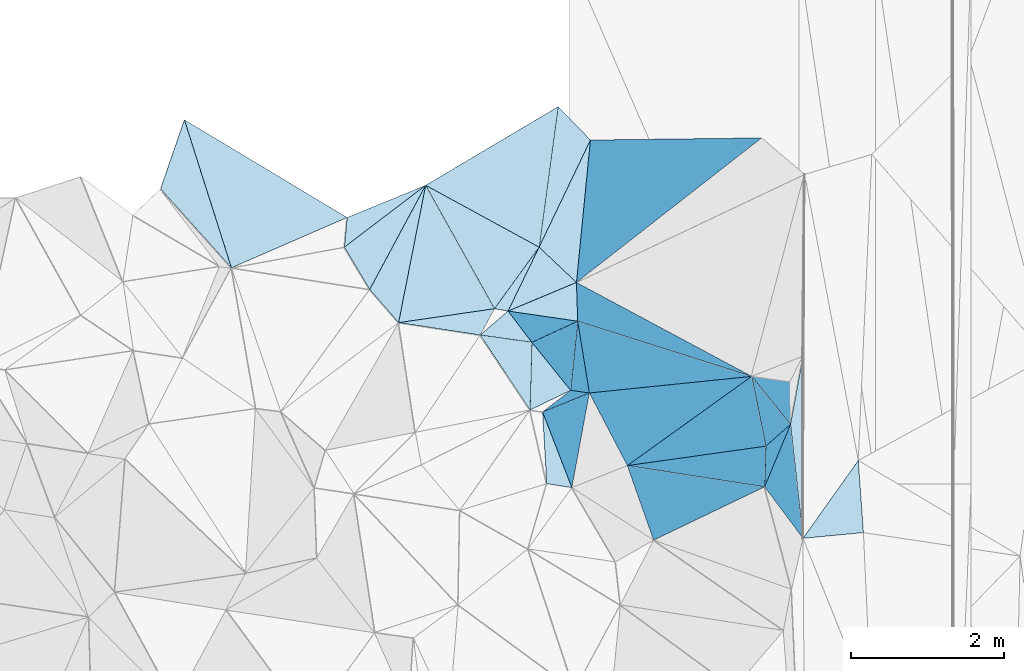
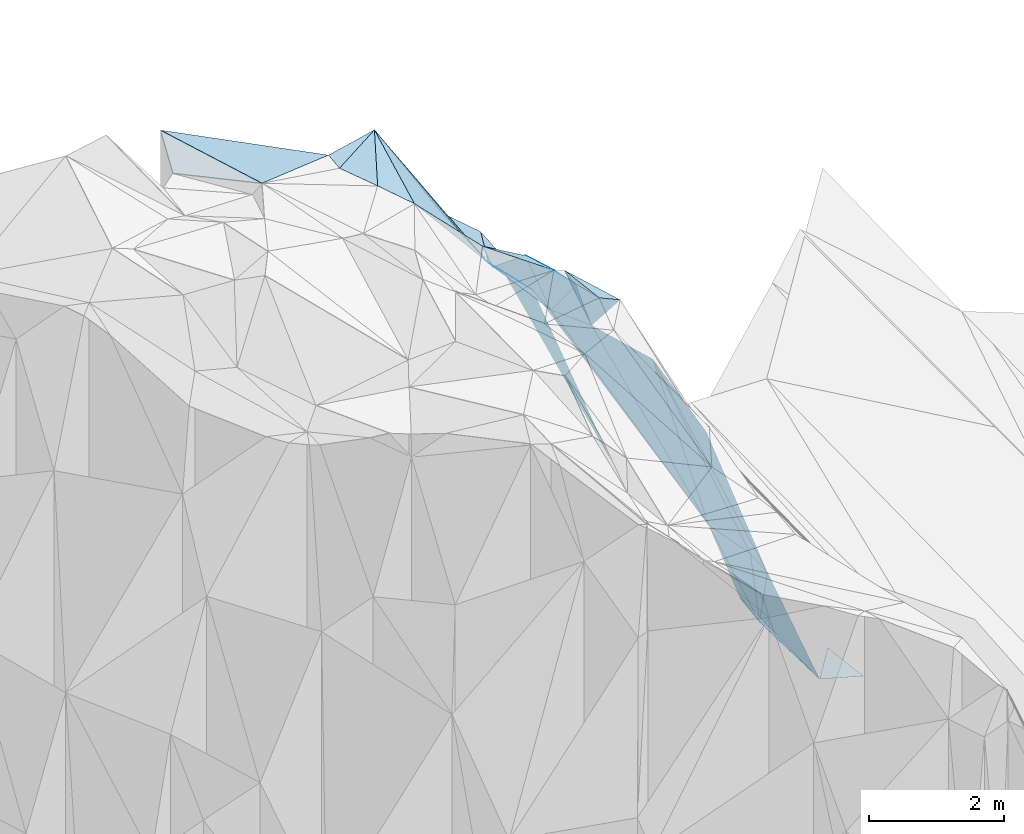
# One storey, part 143 of 275: 36 plates.
"""IFC2X3 building model written with IfcOpenShell, lengths in millimetres."""

from ifc_helpers import new_model, si_unit, frame, origin_with_axes, place, context, subcontext, project, spatial, polyline, outline, extrude, material, type_object, element, save


model = new_model("IFC2X3")

# Units and contexts
model_context = context("Model", 3, precision=1e-05, world=origin_with_axes())
body_context = subcontext(model_context, "Body", "Model", "MODEL_VIEW")
ifc_project = project(units=[si_unit("LENGTHUNIT", "METRE", prefix="MILLI"), si_unit("AREAUNIT", "SQUARE_METRE"), si_unit("VOLUMEUNIT", "CUBIC_METRE"), si_unit("MASSUNIT", "GRAM", prefix="KILO"), si_unit("TIMEUNIT", "SECOND"), si_unit("PLANEANGLEUNIT", "RADIAN"), si_unit("SOLIDANGLEUNIT", "STERADIAN"), si_unit("THERMODYNAMICTEMPERATUREUNIT", "DEGREE_CELSIUS"), si_unit("LUMINOUSINTENSITYUNIT", "LUMEN")], contexts=[model_context])

# Site, building, storey
site_placement = place(None, origin_with_axes())
site = spatial("IfcSite", under=ifc_project, at=site_placement, CompositionType="ELEMENT")
building_placement = place(site_placement, origin_with_axes())
building = spatial("IfcBuilding", under=site, at=building_placement, Name="Undefined", CompositionType="ELEMENT")
storey_placement = place(building_placement, origin_with_axes())
storey = spatial("IfcBuildingStorey", under=building, at=storey_placement, Name="Undefined", CompositionType="ELEMENT", Elevation=0.0)

# Plates
ifc_material = material()
plate_type_1 = type_object("IfcPlateType", PredefinedType="NOTDEFINED")
plate_1_placement = place(storey_placement, frame((-102547.720797669, 135900.673619352, 52969.6947280078), z_axis=(-0.768363652866113, 0.192112177664425, -0.610499965722583), x_axis=(0.364064629516418, -0.653326157836774, -0.663793549999781)))
element("IfcPlate", 1, at=plate_1_placement, inside=storey, type_object=plate_type_1, material=ifc_material, Name="00", context=body_context, shape_type="SweptSolid", body=[
    extrude(outline(polyline([(0.0, 0.0), (2470.64770507813, 2.22753442358226e-08), (1124.52294921875, 1449.94763183594), (0.0, 0.0)])), frame((-8.85201319254618e-08, 2.18876761149539e-07, -0.5000001331573), z_axis=(0.0, 0.0, 1.0), x_axis=(1.0, 0.0, 0.0)), (0.0, 0.0, 1.0), 1.0),
])
plate_type_2 = type_object("IfcPlateType", PredefinedType="NOTDEFINED")
plate_2_placement = place(storey_placement, frame((-101470.606874109, 134255.650710094, 51119.665579446), z_axis=(-0.742247574985633, 0.0421685093330211, -0.668797693064636), x_axis=(0.652550710898406, 0.272550598345937, -0.707031640768118)))
element("IfcPlate", 2, at=plate_2_placement, inside=storey, type_object=plate_type_2, material=ifc_material, Name="00", context=body_context, shape_type="SweptSolid", body=[
    extrude(outline(polyline([(0.0, 0.0), (1371.93298339844, 2.2409949451685e-09), (1279.80017089844, 501.010528564453), (0.0, 0.0)])), frame((-8.85201319254618e-08, 2.18876761149539e-07, -0.5000001331573), z_axis=(0.0, 0.0, 1.0), x_axis=(1.0, 0.0, 0.0)), (0.0, 0.0, 1.0), 1.0),
])
plate_type_3 = type_object("IfcPlateType", PredefinedType="NOTDEFINED")
plate_3_placement = place(storey_placement, frame((-100559.148900787, 134122.735133682, 50099.7876835588), z_axis=(-0.870193036544903, -0.249975786762765, -0.424589431311118), x_axis=(0.467735877350666, -0.148233062743745, -0.871349590089197)))
element("IfcPlate", 3, at=plate_3_placement, inside=storey, type_object=plate_type_3, material=ifc_material, Name="00", context=body_context, shape_type="SweptSolid", body=[
    extrude(outline(polyline([(0.0, 0.0), (4866.0146484375, 1.09575921669602e-08), (1.31524467468262, 980.611145019531), (0.0, 0.0)])), frame((-8.85201319254618e-08, 2.18876761149539e-07, -0.5000001331573), z_axis=(0.0, 0.0, 1.0), x_axis=(1.0, 0.0, 0.0)), (0.0, 0.0, 1.0), 1.0),
])
plate_type_4 = type_object("IfcPlateType", PredefinedType="NOTDEFINED")
plate_4_placement = place(storey_placement, frame((-99909.9735898074, 132233.879680384, 50129.7923177024), z_axis=(-0.840654594332823, -0.347576580985384, -0.415319603892746), x_axis=(-0.454552533351274, 0.869738022446683, 0.192192004866156)))
element("IfcPlate", 4, at=plate_4_placement, inside=storey, type_object=plate_type_4, material=ifc_material, Name="00", context=body_context, shape_type="SweptSolid", body=[
    extrude(outline(polyline([(0.0, 0.0), (1092.65734863281, 1.22454366646707e-08), (-544.72705078125, 4684.64208984375), (0.0, 0.0)])), frame((-8.85201319254618e-08, 2.18876761149539e-07, -0.5000001331573), z_axis=(0.0, 0.0, 1.0), x_axis=(1.0, 0.0, 0.0)), (0.0, 0.0, 1.0), 1.0),
])
plate_type_5 = type_object("IfcPlateType", PredefinedType="NOTDEFINED")
plate_5_placement = place(storey_placement, frame((-101018.126795717, 132935.76946467, 51699.5332070584), z_axis=(-0.351574158053938, -0.0699814600560976, -0.933540682904115), x_axis=(0.360018159528219, -0.930620478831884, -0.0658213429567414)))
element("IfcPlate", 5, at=plate_5_placement, inside=storey, type_object=plate_type_5, material=ifc_material, Name="00", context=body_context, shape_type="SweptSolid", body=[
    extrude(outline(polyline([(0.0, 0.0), (1063.48486328125, -1.35696609504521e-08), (889.340393066406, 308.015747070313), (0.0, 0.0)])), frame((-8.85201319254618e-08, 2.18876761149539e-07, -0.5000001331573), z_axis=(0.0, 0.0, 1.0), x_axis=(1.0, 0.0, 0.0)), (0.0, 0.0, 1.0), 1.0),
])
plate_type_6 = type_object("IfcPlateType", PredefinedType="NOTDEFINED")
plate_6_placement = place(storey_placement, frame((-97775.7304442848, 132773.037217911, 44309.8717734789), z_axis=(-0.963699497185526, -0.0744148932792929, -0.256409248629209), x_axis=(0.108264988592675, -0.986789240296782, -0.120522560043873)))
element("IfcPlate", 6, at=plate_6_placement, inside=storey, type_object=plate_type_6, material=ifc_material, Name="00", context=body_context, shape_type="SweptSolid", body=[
    extrude(outline(polyline([(0.0, 0.0), (1510.09069824219, 1.77969923242927e-08), (587.242858886719, 1648.31604003906), (0.0, 0.0)])), frame((-8.85201319254618e-08, 2.18876761149539e-07, -0.5000001331573), z_axis=(0.0, 0.0, 1.0), x_axis=(1.0, 0.0, 0.0)), (0.0, 0.0, 1.0), 1.0),
])
plate_type_7 = type_object("IfcPlateType", PredefinedType="NOTDEFINED")
plate_7_placement = place(storey_placement, frame((-101063.819890666, 135091.404585895, 50539.6495673656), z_axis=(-0.698116633148106, -0.146566528724808, -0.70082195968699), x_axis=(0.628495325731104, -0.594318196787003, -0.501776351078844)))
element("IfcPlate", 7, at=plate_7_placement, inside=storey, type_object=plate_type_7, material=ifc_material, Name="00", context=body_context, shape_type="SweptSolid", body=[
    extrude(outline(polyline([(0.0, 0.0), (777.238708496094, 2.08819983527064e-09), (-49.9203147888184, 1094.53552246094), (0.0, 0.0)])), frame((-8.85201319254618e-08, 2.18876761149539e-07, -0.5000001331573), z_axis=(0.0, 0.0, 1.0), x_axis=(1.0, 0.0, 0.0)), (0.0, 0.0, 1.0), 1.0),
])
plate_type_8 = type_object("IfcPlateType", PredefinedType="NOTDEFINED")
plate_8_placement = place(storey_placement, frame((-102547.755945151, 135900.617595115, 52969.7305922935), z_axis=(-0.838638010250996, 0.0800739932029449, -0.538771234732131), x_axis=(0.501311733251364, -0.273347609580305, -0.820955315739686)))
element("IfcPlate", 8, at=plate_8_placement, inside=storey, type_object=plate_type_8, material=ifc_material, Name="00", context=body_context, shape_type="SweptSolid", body=[
    extrude(outline(polyline([(0.0, 0.0), (2959.96630859375, -3.63797880709171e-10), (2238.50537109375, 1045.55920410156), (0.0, 0.0)])), frame((-8.85201319254618e-08, 2.18876761149539e-07, -0.5000001331573), z_axis=(0.0, 0.0, 1.0), x_axis=(1.0, 0.0, 0.0)), (0.0, 0.0, 1.0), 1.0),
])
plate_type_9 = type_object("IfcPlateType", PredefinedType="NOTDEFINED")
plate_9_placement = place(storey_placement, frame((-97611.9167991548, 131282.906813317, 44127.5263774031), z_axis=(-0.316264151614978, -0.0526468642125146, -0.947209213474957), x_axis=(0.563116994412564, 0.79311296105914, -0.232101446793775)))
element("IfcPlate", 9, at=plate_9_placement, inside=storey, type_object=plate_type_9, material=ifc_material, Name="00", context=body_context, shape_type="SweptSolid", body=[
    extrude(outline(polyline([(0.0, 0.0), (1283.92138671875, 1.2019881978631e-08), (566.579895019531, 617.107177734375), (0.0, 0.0)])), frame((-8.85201319254618e-08, 2.18876761149539e-07, -0.5000001331573), z_axis=(0.0, 0.0, 1.0), x_axis=(1.0, 0.0, 0.0)), (0.0, 0.0, 1.0), 1.0),
])
plate_type_10 = type_object("IfcPlateType", PredefinedType="NOTDEFINED")
plate_10_placement = place(storey_placement, frame((-98283.1765916622, 133401.575000467, 45859.8375277752), z_axis=(-0.944972946793245, 0.0382884073400537, -0.324900181120685), x_axis=(0.32307635621108, -0.0469877747993295, -0.945205700933283)))
element("IfcPlate", 10, at=plate_10_placement, inside=storey, type_object=plate_type_10, material=ifc_material, Name="00", context=body_context, shape_type="SweptSolid", body=[
    extrude(outline(polyline([(0.0, 0.0), (1555.21704101563, -2.05182004719973e-09), (1658.54663085938, 551.564147949219), (0.0, 0.0)])), frame((-8.85201319254618e-08, 2.18876761149539e-07, -0.5000001331573), z_axis=(0.0, 0.0, 1.0), x_axis=(1.0, 0.0, 0.0)), (0.0, 0.0, 1.0), 1.0),
])
plate_type_11 = type_object("IfcPlateType", PredefinedType="NOTDEFINED")
plate_11_placement = place(storey_placement, frame((-101648.186491519, 134286.2018043, 51329.7033202334), z_axis=(-0.650613746785021, -0.474003135917019, -0.59331507619071), x_axis=(-0.300900917846042, -0.556430451199337, 0.774495829954889)))
element("IfcPlate", 11, at=plate_11_placement, inside=storey, type_object=plate_type_11, material=ifc_material, Name="00", context=body_context, shape_type="SweptSolid", body=[
    extrude(outline(polyline([(0.0, 0.0), (619.757995605469, 2.5902409106493e-09), (1655.80749511719, 1082.91333007813), (0.0, 0.0)])), frame((-8.85201319254618e-08, 2.18876761149539e-07, -0.5000001331573), z_axis=(0.0, 0.0, 1.0), x_axis=(1.0, 0.0, 0.0)), (0.0, 0.0, 1.0), 1.0),
])
plate_type_12 = type_object("IfcPlateType", PredefinedType="NOTDEFINED")
plate_12_placement = place(storey_placement, frame((-98283.1563080278, 133401.470654992, 45859.8043944428), z_axis=(-0.904406052009142, -0.17040623897126, -0.391166725078843), x_axis=(0.198488418499811, -0.97957474166873, -0.0321818769820025)))
element("IfcPlate", 12, at=plate_12_placement, inside=storey, type_object=plate_type_12, material=ifc_material, Name="00", context=body_context, shape_type="SweptSolid", body=[
    extrude(outline(polyline([(0.0, 0.0), (932.201721191406, 5.2241375669837e-09), (683.328491210938, 4666.43994140625), (0.0, 0.0)])), frame((-8.85201319254618e-08, 2.18876761149539e-07, -0.5000001331573), z_axis=(0.0, 0.0, 1.0), x_axis=(1.0, 0.0, 0.0)), (0.0, 0.0, 1.0), 1.0),
])
plate_type_13 = type_object("IfcPlateType", PredefinedType="NOTDEFINED")
plate_13_placement = place(storey_placement, frame((-101018.359486853, 132936.057964006, 51699.8625819703), z_axis=(-0.816950202161776, 0.507032932461061, -0.274790779662949), x_axis=(0.499785035997721, 0.384695510345348, -0.776031108985258)))
element("IfcPlate", 13, at=plate_13_placement, inside=storey, type_object=plate_type_13, material=ifc_material, Name="00", context=body_context, shape_type="SweptSolid", body=[
    extrude(outline(polyline([(0.0, 0.0), (734.506652832031, 8.14907252788544e-10), (1456.76013183594, 404.289337158203), (0.0, 0.0)])), frame((-8.85201319254618e-08, 2.18876761149539e-07, -0.5000001331573), z_axis=(0.0, 0.0, 1.0), x_axis=(1.0, 0.0, 0.0)), (0.0, 0.0, 1.0), 1.0),
])
plate_type_14 = type_object("IfcPlateType", PredefinedType="NOTDEFINED")
plate_14_placement = place(storey_placement, frame((-98114.4370545778, 131956.401024468, 45819.8993095386), z_axis=(-0.978941131404553, 0.0337312167643219, -0.201336698741119), x_axis=(0.030571279460601, 0.999356062030376, 0.0187845190324848)))
element("IfcPlate", 14, at=plate_14_placement, inside=storey, type_object=plate_type_14, material=ifc_material, Name="00", context=body_context, shape_type="SweptSolid", body=[
    extrude(outline(polyline([(0.0, 0.0), (532.353271484375, -1.86264514923096e-09), (798.154235839844, 1557.16088867188), (0.0, 0.0)])), frame((-8.85201319254618e-08, 2.18876761149539e-07, -0.5000001331573), z_axis=(0.0, 0.0, 1.0), x_axis=(1.0, 0.0, 0.0)), (0.0, 0.0, 1.0), 1.0),
])
plate_type_15 = type_object("IfcPlateType", PredefinedType="NOTDEFINED")
plate_15_placement = place(storey_placement, frame((-101182.734781544, 132961.411314122, 51739.6549112046), z_axis=(-0.695684846197324, -0.199345828243929, -0.690133201297509), x_axis=(0.0259194895117173, 0.953132328305207, -0.30144144506512)))
element("IfcPlate", 15, at=plate_15_placement, inside=storey, type_object=plate_type_15, material=ifc_material, Name="00", context=body_context, shape_type="SweptSolid", body=[
    extrude(outline(polyline([(0.0, 0.0), (928.870300292969, -4.68571670353413e-09), (442.472991943359, 724.442993164063), (0.0, 0.0)])), frame((-8.85201319254618e-08, 2.18876761149539e-07, -0.5000001331573), z_axis=(0.0, 0.0, 1.0), x_axis=(1.0, 0.0, 0.0)), (0.0, 0.0, 1.0), 1.0),
])
plate_type_16 = type_object("IfcPlateType", PredefinedType="NOTDEFINED")
plate_16_placement = place(storey_placement, frame((-98283.1809260415, 133401.463121493, 45859.8814688676), z_axis=(-0.953641002807578, -0.185446753951505, -0.237019702162093), x_axis=(0.290330300353368, -0.359572808788442, -0.886800829880483)))
element("IfcPlate", 16, at=plate_16_placement, inside=storey, type_object=plate_type_16, material=ifc_material, Name="00", context=body_context, shape_type="SweptSolid", body=[
    extrude(outline(polyline([(0.0, 0.0), (1747.85583496094, 8.23638401925564e-09), (408.672149658203, 837.8466796875), (0.0, 0.0)])), frame((-8.85201319254618e-08, 2.18876761149539e-07, -0.5000001331573), z_axis=(0.0, 0.0, 1.0), x_axis=(1.0, 0.0, 0.0)), (0.0, 0.0, 1.0), 1.0),
])
plate_type_17 = type_object("IfcPlateType", PredefinedType="NOTDEFINED")
plate_17_placement = place(storey_placement, frame((-99910.0141002454, 132234.071204737, 50129.8068397406), z_axis=(-0.9217008505219, 0.0354564449155912, -0.386277597928165), x_axis=(0.387727918124008, 0.0544269721794728, -0.920165618900531)))
element("IfcPlate", 17, at=plate_17_placement, inside=storey, type_object=plate_type_17, material=ifc_material, Name="00", context=body_context, shape_type="SweptSolid", body=[
    extrude(outline(polyline([(0.0, 0.0), (4673.07177734375, -1.55414454638958e-08), (4647.0078125, 531.71484375), (0.0, 0.0)])), frame((-8.85201319254618e-08, 2.18876761149539e-07, -0.5000001331573), z_axis=(0.0, 0.0, 1.0), x_axis=(1.0, 0.0, 0.0)), (0.0, 0.0, 1.0), 1.0),
])
plate_type_18 = type_object("IfcPlateType", PredefinedType="NOTDEFINED")
plate_18_placement = place(storey_placement, frame((-100651.254683559, 133218.158134481, 51129.7818658071), z_axis=(-0.798197490398763, -0.415439519310514, -0.436223305333593), x_axis=(-0.58155599237804, 0.720254554547442, 0.378187789838406)))
element("IfcPlate", 18, at=plate_18_placement, inside=storey, type_object=plate_type_18, material=ifc_material, Name="00", context=body_context, shape_type="SweptSolid", body=[
    extrude(outline(polyline([(0.0, 0.0), (872.582397460938, 6.8466761149466e-09), (208.347091674805, 1357.97326660156), (0.0, 0.0)])), frame((-8.85201319254618e-08, 2.18876761149539e-07, -0.5000001331573), z_axis=(0.0, 0.0, 1.0), x_axis=(1.0, 0.0, 0.0)), (0.0, 0.0, 1.0), 1.0),
])
plate_type_19 = type_object("IfcPlateType", PredefinedType="NOTDEFINED")
plate_19_placement = place(storey_placement, frame((-103279.130796301, 134538.430077462, 53039.5108804515), z_axis=(-0.199712129743573, 0.0570077513910241, -0.978194858662949), x_axis=(-0.508587728450571, 0.847268755575938, 0.15321285290174)))
element("IfcPlate", 19, at=plate_19_placement, inside=storey, type_object=plate_type_19, material=ifc_material, Name="00", context=body_context, shape_type="SweptSolid", body=[
    extrude(outline(polyline([(0.0, 0.0), (652.686767578125, -1.64436642080545e-09), (771.273498535156, 1341.98999023438), (0.0, 0.0)])), frame((-8.85201319254618e-08, 2.18876761149539e-07, -0.5000001331573), z_axis=(0.0, 0.0, 1.0), x_axis=(1.0, 0.0, 0.0)), (0.0, 0.0, 1.0), 1.0),
])
plate_type_20 = type_object("IfcPlateType", PredefinedType="NOTDEFINED")
plate_20_placement = place(storey_placement, frame((-100406.690321519, 133184.267466752, 50339.8601959452), z_axis=(-0.933817187392323, -0.223225961972481, -0.279563285200598), x_axis=(-0.295553826098575, 0.0410613268023288, 0.954443242586863)))
element("IfcPlate", 20, at=plate_20_placement, inside=storey, type_object=plate_type_20, material=ifc_material, Name="00", context=body_context, shape_type="SweptSolid", body=[
    extrude(outline(polyline([(0.0, 0.0), (827.707702636719, 8.73114913702011e-11), (-145.461990356445, 969.763305664063), (0.0, 0.0)])), frame((-8.85201319254618e-08, 2.18876761149539e-07, -0.5000001331573), z_axis=(0.0, 0.0, 1.0), x_axis=(1.0, 0.0, 0.0)), (0.0, 0.0, 1.0), 1.0),
])
plate_type_21 = type_object("IfcPlateType", PredefinedType="NOTDEFINED")
plate_21_placement = place(storey_placement, frame((-100635.501717829, 131945.954870356, 51629.7818082425), z_axis=(-0.849131203819933, -0.297631802269538, -0.436338754842036), x_axis=(-0.360018159502027, 0.930620478841927, 0.0658213429580121)))
element("IfcPlate", 21, at=plate_21_placement, inside=storey, type_object=plate_type_21, material=ifc_material, Name="00", context=body_context, shape_type="SweptSolid", body=[
    extrude(outline(polyline([(0.0, 0.0), (1063.48486328125, -1.35696609504521e-08), (985.063415527344, 1509.78479003906), (0.0, 0.0)])), frame((-8.85201319254618e-08, 2.18876761149539e-07, -0.5000001331573), z_axis=(0.0, 0.0, 1.0), x_axis=(1.0, 0.0, 0.0)), (0.0, 0.0, 1.0), 1.0),
])
plate_type_22 = type_object("IfcPlateType", PredefinedType="NOTDEFINED")
plate_22_placement = place(storey_placement, frame((-101063.895023202, 135091.493492963, 50539.7357472379), z_axis=(-0.848381545842891, 0.0312438904735576, -0.52846246033309), x_axis=(-0.501311733249459, 0.273347609588251, 0.820955315738203)))
element("IfcPlate", 22, at=plate_22_placement, inside=storey, type_object=plate_type_22, material=ifc_material, Name="00", context=body_context, shape_type="SweptSolid", body=[
    extrude(outline(polyline([(0.0, 0.0), (2959.96630859375, -3.63797880709171e-10), (139.663757324219, 1871.33483886719), (0.0, 0.0)])), frame((-8.85201319254618e-08, 2.18876761149539e-07, -0.5000001331573), z_axis=(0.0, 0.0, 1.0), x_axis=(1.0, 0.0, 0.0)), (0.0, 0.0, 1.0), 1.0),
])
plate_type_23 = type_object("IfcPlateType", PredefinedType="NOTDEFINED")
plate_23_placement = place(storey_placement, frame((-101470.619086875, 134255.594736129, 51119.6808585389), z_axis=(-0.766669445337055, -0.0697786083856737, -0.638238910909019), x_axis=(-0.641786779216758, 0.111318079618435, 0.758760841881449)))
element("IfcPlate", 23, at=plate_23_placement, inside=storey, type_object=plate_type_23, material=ifc_material, Name="00", context=body_context, shape_type="SweptSolid", body=[
    extrude(outline(polyline([(0.0, 0.0), (276.767059326172, -1.61526259034872e-09), (-608.092590332031, 911.440246582031), (0.0, 0.0)])), frame((-8.85201319254618e-08, 2.18876761149539e-07, -0.5000001331573), z_axis=(0.0, 0.0, 1.0), x_axis=(1.0, 0.0, 0.0)), (0.0, 0.0, 1.0), 1.0),
])
plate_type_24 = type_object("IfcPlateType", PredefinedType="NOTDEFINED")
plate_24_placement = place(storey_placement, frame((-102901.321509306, 134104.169398072, 52849.531474398), z_axis=(-0.325520462381704, 0.126702389917276, -0.937007434847799), x_axis=(-0.623327467465893, 0.716401825511133, 0.313418717862977)))
element("IfcPlate", 24, at=plate_24_placement, inside=storey, type_object=plate_type_24, material=ifc_material, Name="00", context=body_context, shape_type="SweptSolid", body=[
    extrude(outline(polyline([(0.0, 0.0), (606.2177734375, -8.06358002591878e-09), (1104.05871582031, 1465.59008789063), (0.0, 0.0)])), frame((-8.85201319254618e-08, 2.18876761149539e-07, -0.5000001331573), z_axis=(0.0, 0.0, 1.0), x_axis=(1.0, 0.0, 0.0)), (0.0, 0.0, 1.0), 1.0),
])
plate_type_25 = type_object("IfcPlateType", PredefinedType="NOTDEFINED")
plate_25_placement = place(storey_placement, frame((-100575.290158179, 134629.553772583, 50149.6078609152), z_axis=(-0.620434602906835, 0.0060075857392593, -0.78423517673554), x_axis=(-0.62849532572201, 0.594318196800081, 0.501776351074744)))
element("IfcPlate", 25, at=plate_25_placement, inside=storey, type_object=plate_type_25, material=ifc_material, Name="00", context=body_context, shape_type="SweptSolid", body=[
    extrude(outline(polyline([(0.0, 0.0), (777.238708496094, 2.08819983527064e-09), (927.256958007813, 1631.07153320313), (0.0, 0.0)])), frame((-8.85201319254618e-08, 2.18876761149539e-07, -0.5000001331573), z_axis=(0.0, 0.0, 1.0), x_axis=(1.0, 0.0, 0.0)), (0.0, 0.0, 1.0), 1.0),
])
plate_type_26 = type_object("IfcPlateType", PredefinedType="NOTDEFINED")
plate_26_placement = place(storey_placement, frame((-101158.583819831, 133846.476588817, 51459.8045061105), z_axis=(-0.545455943730404, -0.741377580504434, -0.390943853480991), x_axis=(-0.506008611283995, 0.663132534782559, -0.551552832119735)))
element("IfcPlate", 26, at=plate_26_placement, inside=storey, type_object=plate_type_26, material=ifc_material, Name="00", context=body_context, shape_type="SweptSolid", body=[
    extrude(outline(polyline([(0.0, 0.0), (616.44140625, 1.01863406598568e-10), (629.743530273438, 1374.30822753906), (0.0, 0.0)])), frame((-8.85201319254618e-08, 2.18876761149539e-07, -0.5000001331573), z_axis=(0.0, 0.0, 1.0), x_axis=(1.0, 0.0, 0.0)), (0.0, 0.0, 1.0), 1.0),
])
plate_type_27 = type_object("IfcPlateType", PredefinedType="NOTDEFINED")
plate_27_placement = place(storey_placement, frame((-101182.623192513, 132961.383971463, 51739.5780214652), z_axis=(-0.472515907767492, -0.254049412837188, -0.84391208827919), x_axis=(-0.552885826644017, 0.831139789975048, 0.059362548937822)))
element("IfcPlate", 27, at=plate_27_placement, inside=storey, type_object=plate_type_27, material=ifc_material, Name="00", context=body_context, shape_type="SweptSolid", body=[
    extrude(outline(polyline([(0.0, 0.0), (1179.19458007813, 2.48837750405073e-09), (705.905517578125, 603.736206054688), (0.0, 0.0)])), frame((-8.85201319254618e-08, 2.18876761149539e-07, -0.5000001331573), z_axis=(0.0, 0.0, 1.0), x_axis=(1.0, 0.0, 0.0)), (0.0, 0.0, 1.0), 1.0),
])
plate_type_28 = type_object("IfcPlateType", PredefinedType="NOTDEFINED")
plate_28_placement = place(storey_placement, frame((-99566.7094345344, 131259.661860848, 49299.8076237811), z_axis=(-0.923034416601711, 0.00248986400300805, -0.38470932708473), x_axis=(-0.259055943469671, 0.735270441979174, 0.626312538038948)))
element("IfcPlate", 28, at=plate_28_placement, inside=storey, type_object=plate_type_28, material=ifc_material, Name="00", context=body_context, shape_type="SweptSolid", body=[
    extrude(outline(polyline([(0.0, 0.0), (1325.21691894531, -7.73434294387698e-09), (-2043.51440429688, 3244.849609375), (0.0, 0.0)])), frame((-8.85201319254618e-08, 2.18876761149539e-07, -0.5000001331573), z_axis=(0.0, 0.0, 1.0), x_axis=(1.0, 0.0, 0.0)), (0.0, 0.0, 1.0), 1.0),
])
plate_type_29 = type_object("IfcPlateType", PredefinedType="NOTDEFINED")
plate_29_placement = place(storey_placement, frame((-100815.427934507, 136928.739113229, 50249.5759968205), z_axis=(-0.526334024152912, -0.062710268709342, -0.84796221449862), x_axis=(0.650528775791928, -0.671883285849083, -0.354097673055465)))
element("IfcPlate", 29, at=plate_29_placement, inside=storey, type_object=plate_type_29, material=ifc_material, Name="00", context=body_context, shape_type="SweptSolid", body=[
    extrude(outline(polyline([(0.0, 0.0), (649.538269042969, 4.31100488640368e-09), (970.227600097656, 1606.25598144531), (0.0, 0.0)])), frame((-8.85201319254618e-08, 2.18876761149539e-07, -0.5000001331573), z_axis=(0.0, 0.0, 1.0), x_axis=(1.0, 0.0, 0.0)), (0.0, 0.0, 1.0), 1.0),
])
plate_type_30 = type_object("IfcPlateType", PredefinedType="NOTDEFINED")
plate_30_placement = place(storey_placement, frame((-98283.1439054421, 133401.565183984, 45859.7623074605), z_axis=(-0.879602922213033, 0.018668930890532, -0.475342161241455), x_axis=(-0.467735877353604, 0.148233062753228, 0.871349590086007)))
element("IfcPlate", 30, at=plate_30_placement, inside=storey, type_object=plate_type_30, material=ifc_material, Name="00", context=body_context, shape_type="SweptSolid", body=[
    extrude(outline(polyline([(0.0, 0.0), (4866.0146484375, 1.09575921669602e-08), (4992.298828125, 493.510223388672), (0.0, 0.0)])), frame((-8.85201319254618e-08, 2.18876761149539e-07, -0.5000001331573), z_axis=(0.0, 0.0, 1.0), x_axis=(1.0, 0.0, 0.0)), (0.0, 0.0, 1.0), 1.0),
])
plate_type_31 = type_object("IfcPlateType", PredefinedType="NOTDEFINED")
plate_31_placement = place(storey_placement, frame((-97612.3862604992, 133665.254761849, 44189.6241363391), z_axis=(-0.659234985029907, 0.0194802344623963, -0.751684611374949), x_axis=(0.0001250465721382, -0.999661510153988, -0.0260163310250203)))
element("IfcPlate", 31, at=plate_31_placement, inside=storey, type_object=plate_type_31, material=ifc_material, Name="00", context=body_context, shape_type="SweptSolid", body=[
    extrude(outline(polyline([(0.0, 0.0), (2383.11865234375, -1.52795109897852e-08), (888.726257324219, 217.176559448242), (0.0, 0.0)])), frame((-8.85201319254618e-08, 2.18876761149539e-07, -0.5000001331573), z_axis=(0.0, 0.0, 1.0), x_axis=(1.0, 0.0, 0.0)), (0.0, 0.0, 1.0), 1.0),
])
plate_type_32 = type_object("IfcPlateType", PredefinedType="NOTDEFINED")
plate_32_placement = place(storey_placement, frame((-101470.428582016, 134255.25666226, 51119.7284731698), z_axis=(-0.385662800400157, -0.745925272126407, -0.543009845942645), x_axis=(0.506008611294413, -0.663132534774138, 0.551552832120303)))
element("IfcPlate", 32, at=plate_32_placement, inside=storey, type_object=plate_type_32, material=ifc_material, Name="00", context=body_context, shape_type="SweptSolid", body=[
    extrude(outline(polyline([(0.0, 0.0), (616.44140625, 1.01863406598568e-10), (404.580230712891, 737.302429199219), (0.0, 0.0)])), frame((-8.85201319254618e-08, 2.18876761149539e-07, -0.5000001331573), z_axis=(0.0, 0.0, 1.0), x_axis=(1.0, 0.0, 0.0)), (0.0, 0.0, 1.0), 1.0),
])
plate_type_33 = type_object("IfcPlateType", PredefinedType="NOTDEFINED")
plate_33_placement = place(storey_placement, frame((-106014.742649714, 135854.618413688, 53429.5106882444), z_axis=(0.196201493979317, 0.0623683215390764, -0.978578134963521), x_axis=(0.323502515501295, 0.937982124482698, 0.124642114131858)))
element("IfcPlate", 33, at=plate_33_placement, inside=storey, type_object=plate_type_33, material=ifc_material, Name="00", context=body_context, shape_type="SweptSolid", body=[
    extrude(outline(polyline([(0.0, 0.0), (962.756469726563, 2.6775524020195e-09), (-654.474975585938, 1230.18798828125), (0.0, 0.0)])), frame((-8.85201319254618e-08, 2.18876761149539e-07, -0.5000001331573), z_axis=(0.0, 0.0, 1.0), x_axis=(1.0, 0.0, 0.0)), (0.0, 0.0, 1.0), 1.0),
])
plate_type_34 = type_object("IfcPlateType", PredefinedType="NOTDEFINED")
plate_34_placement = place(storey_placement, frame((-103611.054045557, 135091.396906287, 53139.5056123966), z_axis=(-0.149258999056169, -0.0115253265779145, -0.988730963431419), x_axis=(0.0931650974167779, 0.995319799412722, -0.0256663499613917)))
element("IfcPlate", 34, at=plate_34_placement, inside=storey, type_object=plate_type_34, material=ifc_material, Name="00", context=body_context, shape_type="SweptSolid", body=[
    extrude(outline(polyline([(0.0, 0.0), (389.615203857422, -5.29689714312553e-09), (908.845458984375, 994.484741210938), (0.0, 0.0)])), frame((-8.85201319254618e-08, 2.18876761149539e-07, -0.5000001331573), z_axis=(0.0, 0.0, 1.0), x_axis=(1.0, 0.0, 0.0)), (0.0, 0.0, 1.0), 1.0),
])
plate_type_35 = type_object("IfcPlateType", PredefinedType="NOTDEFINED")
plate_35_placement = place(storey_placement, frame((-105703.504742709, 136757.598023194, 53549.5155837001), z_axis=(-0.236246112080755, -0.0750976613423678, -0.968786930025191), x_axis=(0.845270406435753, -0.507645789463205, -0.16677437586217)))
element("IfcPlate", 35, at=plate_35_placement, inside=storey, type_object=plate_type_35, material=ifc_material, Name="00", context=body_context, shape_type="SweptSolid", body=[
    extrude(outline(polyline([(0.0, 0.0), (2518.37255859375, -6.69388100504875e-10), (1503.35192871094, 1367.01611328125), (0.0, 0.0)])), frame((-8.85201319254618e-08, 2.18876761149539e-07, -0.5000001331573), z_axis=(0.0, 0.0, 1.0), x_axis=(1.0, 0.0, 0.0)), (0.0, 0.0, 1.0), 1.0),
])
plate_type_36 = type_object("IfcPlateType", PredefinedType="NOTDEFINED")
plate_36_placement = place(storey_placement, frame((-100393.075716454, 136492.386594632, 50019.7933212725), z_axis=(-0.908602997397449, 0.0601032737046637, -0.41331366975985), x_axis=(0.414341439229105, 0.00519676632001911, -0.910106678009435)))
element("IfcPlate", 36, at=plate_36_placement, inside=storey, type_object=plate_type_36, material=ifc_material, Name="00", context=body_context, shape_type="SweptSolid", body=[
    extrude(outline(polyline([(0.0, 0.0), (5405.95947265625, 8.78935679793358e-09), (-203.553131103516, 1865.14501953125), (0.0, 0.0)])), frame((-8.85201319254618e-08, 2.18876761149539e-07, -0.5000001331573), z_axis=(0.0, 0.0, 1.0), x_axis=(1.0, 0.0, 0.0)), (0.0, 0.0, 1.0), 1.0),
])

save(model, "model.ifc")
